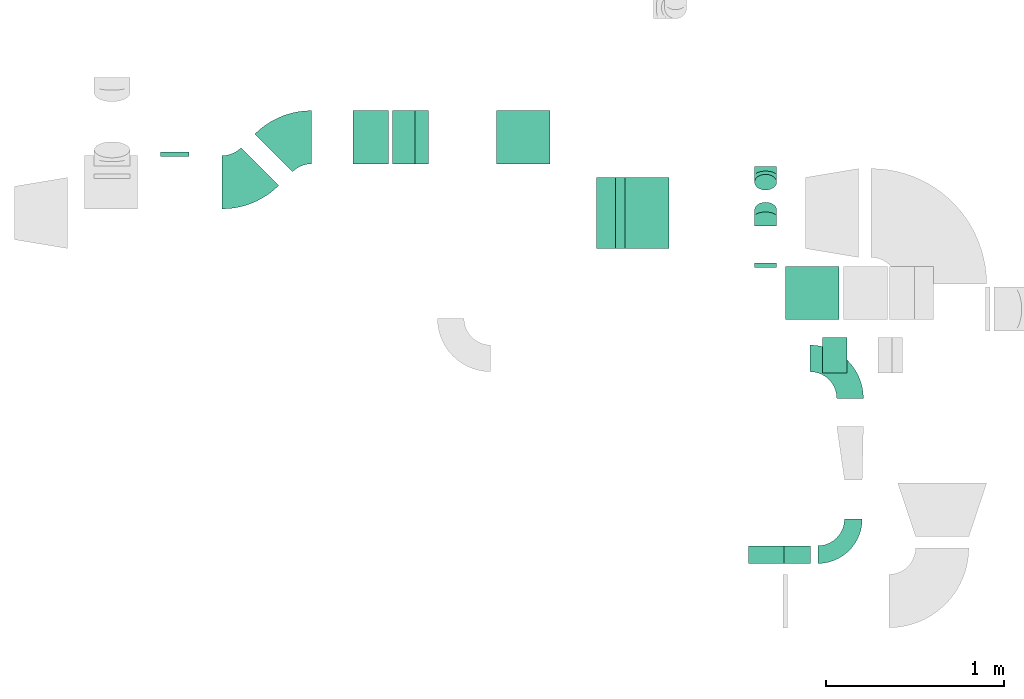
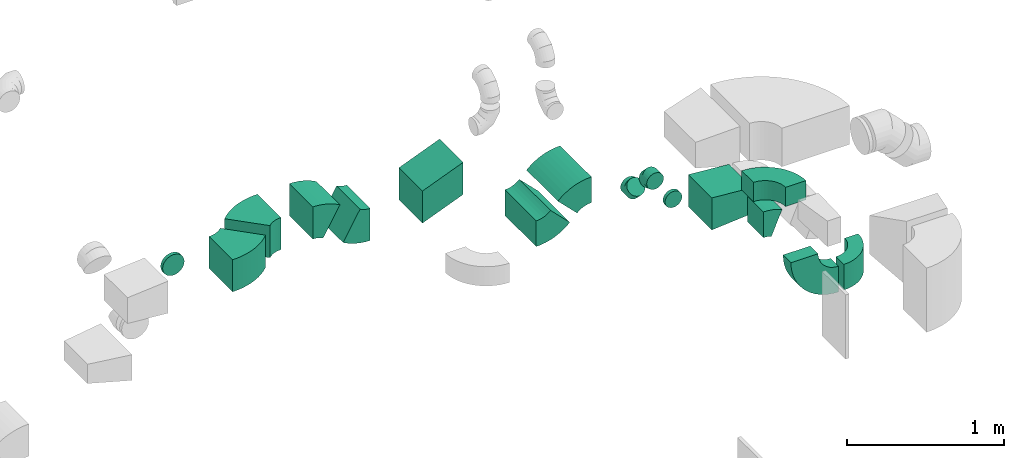
# One storey, part 26 of 44: 16 flow fittings.
"""IFC2X3 building model written with IfcOpenShell, lengths in millimetres."""

from ifc_helpers import new_model, entity, si_unit, converted_unit, derived_unit, direction, frame, frame_2d, origin, place, context, subcontext, project, spatial, polyline, circle_curve, parameter, trimmed, segment, composite_curve, outline, extrude, faceted_brep, source, transform, mapped, material, type_object, type_shapes, element, save


model = new_model("IFC2X3")

# Units and contexts
model_context = context("Model", 3, precision=0.01, world=origin(), true_north=direction((6.12303176911189e-17, 1.0)))
body_context = subcontext(model_context, "Body", "Model", "MODEL_VIEW")
ifc_project = project(units=[si_unit("LENGTHUNIT", "METRE", prefix="MILLI"), si_unit("AREAUNIT", "SQUARE_METRE"), si_unit("VOLUMEUNIT", "CUBIC_METRE"), converted_unit("PLANEANGLEUNIT", "DEGREE", entity("IfcRatioMeasure", 0.0174532925199433), si_unit("PLANEANGLEUNIT", "RADIAN"), dimensions=[0, 0, 0, 0, 0, 0, 0]), si_unit("MASSUNIT", "GRAM", prefix="KILO"), derived_unit("MASSDENSITYUNIT", [(si_unit("MASSUNIT", "GRAM", prefix="KILO"), 1), (si_unit("LENGTHUNIT", "METRE"), -3)]), derived_unit("MOMENTOFINERTIAUNIT", [(si_unit("LENGTHUNIT", "METRE"), 4)]), si_unit("TIMEUNIT", "SECOND"), si_unit("FREQUENCYUNIT", "HERTZ"), si_unit("THERMODYNAMICTEMPERATUREUNIT", "DEGREE_CELSIUS"), derived_unit("THERMALTRANSMITTANCEUNIT", [(si_unit("MASSUNIT", "GRAM", prefix="KILO"), 1), (si_unit("THERMODYNAMICTEMPERATUREUNIT", "KELVIN"), -1), (si_unit("TIMEUNIT", "SECOND"), -3)]), derived_unit("VOLUMETRICFLOWRATEUNIT", [(si_unit("LENGTHUNIT", "METRE"), 3), (si_unit("TIMEUNIT", "SECOND"), -1)]), derived_unit("MASSFLOWRATEUNIT", [(si_unit("MASSUNIT", "GRAM", prefix="KILO"), 1), (si_unit("TIMEUNIT", "SECOND"), -1)]), derived_unit("ROTATIONALFREQUENCYUNIT", [(si_unit("TIMEUNIT", "SECOND"), -1)]), si_unit("ELECTRICCURRENTUNIT", "AMPERE"), si_unit("ELECTRICVOLTAGEUNIT", "VOLT"), si_unit("POWERUNIT", "WATT"), si_unit("FORCEUNIT", "NEWTON", prefix="KILO"), si_unit("ILLUMINANCEUNIT", "LUX"), si_unit("LUMINOUSFLUXUNIT", "LUMEN"), si_unit("LUMINOUSINTENSITYUNIT", "CANDELA"), derived_unit("USERDEFINED", [(si_unit("MASSUNIT", "GRAM", prefix="KILO"), -1), (si_unit("LENGTHUNIT", "METRE"), -2), (si_unit("TIMEUNIT", "SECOND"), 3), (si_unit("LUMINOUSFLUXUNIT", "LUMEN"), 1)]), derived_unit("LINEARVELOCITYUNIT", [(si_unit("LENGTHUNIT", "METRE"), 1), (si_unit("TIMEUNIT", "SECOND"), -1)]), si_unit("PRESSUREUNIT", "PASCAL"), derived_unit("USERDEFINED", [(si_unit("LENGTHUNIT", "METRE"), -2), (si_unit("MASSUNIT", "GRAM", prefix="KILO"), 1), (si_unit("TIMEUNIT", "SECOND"), -2)]), derived_unit("LINEARFORCEUNIT", [(si_unit("MASSUNIT", "GRAM", prefix="KILO"), 1), (si_unit("LENGTHUNIT", "METRE"), 1), (si_unit("TIMEUNIT", "SECOND"), -2), (si_unit("LENGTHUNIT", "METRE"), -1)]), derived_unit("PLANARFORCEUNIT", [(si_unit("MASSUNIT", "GRAM", prefix="KILO"), 1), (si_unit("LENGTHUNIT", "METRE"), 1), (si_unit("TIMEUNIT", "SECOND"), -2), (si_unit("LENGTHUNIT", "METRE"), -2)])], contexts=[model_context])

# Site, building, storey
site_placement = place(None, origin())
site = spatial("IfcSite", under=ifc_project, at=site_placement, CompositionType="ELEMENT")
building_placement = place(site_placement, origin())
building = spatial("IfcBuilding", under=site, at=building_placement, CompositionType="ELEMENT")
storey_placement = place(building_placement, frame((0.0, 0.0, 15900.0)))
storey = spatial("IfcBuildingStorey", under=building, at=storey_placement, CompositionType="ELEMENT", Elevation=15900.0)

# Flow fittings
ifc_material = material()
duct_fitting_type_1 = type_object("IfcDuctFittingType", PredefinedType="NOTDEFINED", material=ifc_material)
shared_shape_1 = source(origin(), body_context, "Body", "SweptSolid", [
    extrude(outline(polyline([(-141.18, -112.11), (159.86, -112.11), (139.1, 137.03), (-157.79, 87.2), (-141.18, -112.11)])), frame((150.0, -150.0, 0.0), z_axis=(0.0, 1.0, 0.0), x_axis=(0.996545758244888, 0.0, 0.0830454798536443)), (0.0, 0.0, 1.0), 300.0),
])
type_shapes(duct_fitting_type_1, [shared_shape_1])
flow_fitting_1_placement = place(storey_placement, frame((53059.03, 14525.32, 3075.0), z_axis=(0.0, 0.0, 1.0), x_axis=(-1.0, 0.0, 0.0)))
element("IfcFlowFitting", 1, at=flow_fitting_1_placement, inside=storey, type_object=duct_fitting_type_1, material=ifc_material, context=body_context, shape_type="MappedRepresentation", body=[
    mapped(shared_shape_1, transform((0.0, 0.0, 0.0), scale=1.0)),
])
duct_fitting_type_2 = type_object("IfcDuctFittingType", PredefinedType="NOTDEFINED", material=ifc_material)
shared_shape_2 = source(origin(), body_context, "Body", "SweptSolid", [
    extrude(outline(polyline([(-207.34, -116.22), (115.32, -116.22), (207.34, 116.22), (-115.32, 116.22), (-207.34, -116.22)])), frame((150.0, -150.0, -59.38), z_axis=(0.0, 1.0, 0.0), x_axis=(0.929790028518496, 0.0, -0.368090346066796)), (0.0, 0.0, 1.0), 300.0),
])
type_shapes(duct_fitting_type_2, [shared_shape_2])
flow_fitting_2_placement = place(storey_placement, frame((51433.15, 15401.67, 3284.58), z_axis=(0.0, 0.0, 1.0), x_axis=(-1.0, 0.0, 0.0)))
element("IfcFlowFitting", 2, at=flow_fitting_2_placement, inside=storey, type_object=duct_fitting_type_2, material=ifc_material, context=body_context, shape_type="MappedRepresentation", body=[
    mapped(shared_shape_2, transform((0.0, 0.0, 0.0), scale=1.0)),
])
duct_fitting_type_3 = type_object("IfcDuctFittingType", PredefinedType="NOTDEFINED", material=ifc_material)
shared_shape_3 = source(origin(), body_context, "Body", "Brep", [
    faceted_brep([(-51.78, 0.0, -62.5), (-51.78, -16.18, -60.37), (-51.78, -31.25, -54.13), (-51.78, -44.19, -44.19), (-51.78, -54.13, -31.25), (-51.78, -60.37, -16.18), (-51.78, -62.5, 0.0), (-51.78, -60.37, 16.18), (-51.78, -54.13, 31.25), (-51.78, -44.19, 44.19), (-51.78, -31.25, 54.13), (-51.78, -16.18, 60.37), (-51.78, 0.0, 62.5), (-51.78, 16.18, 60.37), (-51.78, 31.25, 54.13), (-51.78, 44.19, 44.19), (-51.78, 54.13, 31.25), (-51.78, 60.37, 16.18), (-51.78, 62.5, 0.0), (-51.78, 60.37, -16.18), (-51.78, 54.13, -31.25), (-51.78, 44.19, -44.19), (-51.78, 31.25, -54.13), (-51.78, 16.18, -60.37), (-6.7, 16.18, 60.37), (-12.94, 31.25, 54.13), (0.0, 0.0, 62.5), (-18.31, 44.19, 44.19), (-22.42, 54.13, 31.25), (-25.01, 60.37, 16.18), (-25.89, 62.5, 0.0), (-25.01, 60.37, -16.18), (-22.42, 54.13, -31.25), (-18.31, 44.19, -44.19), (-6.7, 16.18, -60.37), (0.0, 0.0, -62.5), (-12.94, 31.25, -54.13), (6.7, -16.18, -60.37), (12.94, -31.25, -54.13), (18.31, -44.19, -44.19), (22.42, -54.13, -31.25), (25.01, -60.37, -16.18), (25.89, -62.5, 0.0), (25.01, -60.37, 16.18), (22.42, -54.13, 31.25), (18.31, -44.19, 44.19), (12.94, -31.25, 54.13), (6.7, -16.18, 60.37), (25.17, 48.05, 60.37), (14.51, 58.71, 54.13), (36.61, 36.61, 62.5), (5.36, 67.86, 44.19), (-1.66, 74.88, 31.25), (-6.08, 79.3, 16.18), (-7.58, 80.81, 0.0), (-6.08, 79.3, -16.18), (-1.66, 74.88, -31.25), (5.36, 67.86, -44.19), (14.51, 58.71, -54.13), (25.17, 48.05, -60.37), (36.61, 36.61, -62.5), (48.05, 25.17, -60.37), (58.71, 14.51, -54.13), (67.86, 5.36, -44.19), (74.88, -1.66, -31.25), (79.3, -6.08, -16.18), (80.81, -7.58, 0.0), (79.3, -6.08, 16.18), (74.88, -1.66, 31.25), (67.86, 5.36, 44.19), (58.71, 14.51, 54.13), (48.05, 25.17, 60.37)], [[[0, 1, 2, 3, 4, 5, 6, 7, 8, 9, 10, 11, 12, 13, 14, 15, 16, 17, 18, 19, 20, 21, 22, 23]], [[24, 25, 14, 13]], [[26, 24, 13, 12]], [[27, 15, 14, 25]], [[28, 29, 17, 16]], [[28, 16, 15, 27]], [[30, 18, 17, 29]], [[31, 32, 20, 19]], [[30, 31, 19, 18]], [[21, 20, 32, 33]], [[34, 35, 0, 23]], [[36, 34, 23, 22]], [[33, 36, 22, 21]], [[1, 0, 35, 37]], [[2, 1, 37, 38]], [[38, 39, 3, 2]], [[5, 4, 40, 41]], [[6, 5, 41, 42]], [[39, 40, 4, 3]], [[6, 42, 43, 7]], [[7, 43, 44, 8]], [[8, 44, 45, 9]], [[9, 45, 46, 10]], [[10, 46, 47, 11]], [[26, 12, 11, 47]], [[48, 49, 25, 24]], [[50, 48, 24, 26]], [[27, 25, 49, 51]], [[29, 28, 52, 53]], [[30, 29, 53, 54]], [[51, 52, 28, 27]], [[30, 54, 55, 31]], [[31, 55, 56, 32]], [[57, 33, 32, 56]], [[36, 58, 59, 34]], [[34, 59, 60, 35]], [[58, 36, 33, 57]], [[35, 60, 61, 37]], [[37, 61, 62, 38]], [[63, 39, 38, 62]], [[40, 64, 65, 41]], [[41, 65, 66, 42]], [[64, 40, 39, 63]], [[43, 42, 66, 67]], [[44, 43, 67, 68]], [[68, 69, 45, 44]], [[47, 46, 70, 71]], [[26, 47, 71, 50]], [[69, 70, 46, 45]], [[59, 58, 57, 56, 55, 54, 53, 52, 51, 49, 48, 50, 71, 70, 69, 68, 67, 66, 65, 64, 63, 62, 61, 60]]]),
])
type_shapes(duct_fitting_type_3, [shared_shape_3])
for number, where, z_axis, x_axis in (
    (3, (52646.56, 15185.32, 2820.0), (-1.0, 0.0, 0.0), (0.0, -1.0, 0.0)),
    (4, (52646.56, 14955.32, 3050.0), (1.0, 0.0, 0.0), (0.0, -0.707106781186459, 0.707106781186636)),
):
    element("IfcFlowFitting", number, at=place(storey_placement, frame(where, z_axis=z_axis, x_axis=x_axis)), inside=storey, type_object=duct_fitting_type_3, material=ifc_material, context=body_context, shape_type="MappedRepresentation", body=[
        mapped(shared_shape_3, transform((0.0, 0.0, 0.0), scale=1.0)),
    ])
duct_fitting_type_4 = type_object("IfcDuctFittingType", PredefinedType="NOTDEFINED", material=ifc_material)
shared_shape_4 = source(origin(), body_context, "Body", "Brep", [
    faceted_brep([(20.0, 16.18, -60.37), (20.0, 31.25, -54.13), (20.0, 44.19, -44.19), (20.0, 54.13, -31.25), (20.0, 60.37, -16.18), (20.0, 62.5, 0.0), (20.0, 60.37, 16.18), (20.0, 54.13, 31.25), (20.0, 44.19, 44.19), (20.0, 31.25, 54.13), (20.0, 16.18, 60.37), (20.0, 0.0, 62.5), (20.0, -16.18, 60.37), (20.0, -31.25, 54.13), (20.0, -44.19, 44.19), (20.0, -54.13, 31.25), (20.0, -60.37, 16.18), (20.0, -62.5, 0.0), (20.0, -60.37, -16.18), (20.0, -54.13, -31.25), (20.0, -44.19, -44.19), (20.0, -31.25, -54.13), (20.0, -16.18, -60.37), (20.0, 0.0, -62.5), (0.0, 0.0, 62.5), (0.0, 16.18, 60.37), (-6.1, 16.18, 60.37), (-6.1, 0.0, 62.5), (0.0, 31.25, 54.13), (-6.1, 31.25, 54.13), (0.0, 44.19, 44.19), (-6.1, 44.19, 44.19), (0.0, 54.13, 31.25), (0.0, 60.37, 16.18), (-6.1, 60.37, 16.18), (-6.1, 54.13, 31.25), (0.0, 62.5, 0.0), (-6.1, 62.5, 0.0), (0.0, 60.37, -16.18), (-6.1, 60.37, -16.18), (0.0, 54.13, -31.25), (-6.1, 54.13, -31.25), (0.0, 44.19, -44.19), (-6.1, 44.19, -44.19), (0.0, 31.25, -54.13), (0.0, 16.18, -60.37), (-6.1, 16.18, -60.37), (-6.1, 31.25, -54.13), (0.0, 0.0, -62.5), (-6.1, 0.0, -62.5), (0.0, -16.18, -60.37), (-6.1, -16.18, -60.37), (0.0, -31.25, -54.13), (-6.1, -31.25, -54.13), (0.0, -44.19, -44.19), (-6.1, -44.19, -44.19), (0.0, -54.13, -31.25), (0.0, -60.37, -16.18), (-6.1, -60.37, -16.18), (-6.1, -54.13, -31.25), (0.0, -62.5, 0.0), (-6.1, -62.5, 0.0), (0.0, -60.37, 16.18), (-6.1, -60.37, 16.18), (0.0, -54.13, 31.25), (-6.1, -54.13, 31.25), (0.0, -44.19, 44.19), (-6.1, -44.19, 44.19), (0.0, -31.25, 54.13), (0.0, -16.18, 60.37), (-6.1, -16.18, 60.37), (-6.1, -31.25, 54.13)], [[[0, 1, 2, 3, 4, 5, 6, 7, 8, 9, 10, 11, 12, 13, 14, 15, 16, 17, 18, 19, 20, 21, 22, 23]], [[24, 11, 10, 25, 26, 27]], [[25, 10, 9, 28, 29, 26]], [[28, 9, 8, 30, 31, 29]], [[32, 7, 6, 33, 34, 35]], [[33, 6, 5, 36, 37, 34]], [[30, 8, 7, 32, 35, 31]], [[36, 5, 4, 38, 39, 37]], [[38, 4, 3, 40, 41, 39]], [[40, 3, 2, 42, 43, 41]], [[44, 1, 0, 45, 46, 47]], [[45, 0, 23, 48, 49, 46]], [[42, 2, 1, 44, 47, 43]], [[48, 23, 22, 50, 51, 49]], [[50, 22, 21, 52, 53, 51]], [[52, 21, 20, 54, 55, 53]], [[56, 19, 18, 57, 58, 59]], [[57, 18, 17, 60, 61, 58]], [[54, 20, 19, 56, 59, 55]], [[60, 17, 16, 62, 63, 61]], [[62, 16, 15, 64, 65, 63]], [[64, 15, 14, 66, 67, 65]], [[68, 13, 12, 69, 70, 71]], [[69, 12, 11, 24, 27, 70]], [[66, 14, 13, 68, 71, 67]], [[49, 51, 53, 55, 59, 58, 61, 63, 65, 67, 71, 70, 27, 26, 29, 31, 35, 34, 37, 39, 41, 43, 47, 46]]]),
])
type_shapes(duct_fitting_type_4, [shared_shape_4])
flow_fitting_3_placement = place(storey_placement, frame((52646.56, 14675.32, 3050.0), z_axis=(0.0, 0.0, -1.0), x_axis=(0.0, 1.0, 0.0)))
element("IfcFlowFitting", 5, at=flow_fitting_3_placement, inside=storey, type_object=duct_fitting_type_4, material=ifc_material, context=body_context, shape_type="MappedRepresentation", body=[
    mapped(shared_shape_4, transform((0.0, 0.0, 0.0), scale=1.0)),
])
duct_fitting_type_5 = type_object("IfcDuctFittingType", PredefinedType="NOTDEFINED", material=ifc_material)
shared_shape_5 = source(origin(), body_context, "Body", "Brep", [
    faceted_brep([(20.0, 20.71, -77.27), (20.0, 40.0, -69.28), (20.0, 56.57, -56.57), (20.0, 69.28, -40.0), (20.0, 77.27, -20.71), (20.0, 80.0, 0.0), (20.0, 77.27, 20.71), (20.0, 69.28, 40.0), (20.0, 56.57, 56.57), (20.0, 40.0, 69.28), (20.0, 20.71, 77.27), (20.0, 0.0, 80.0), (20.0, -20.71, 77.27), (20.0, -40.0, 69.28), (20.0, -56.57, 56.57), (20.0, -69.28, 40.0), (20.0, -77.27, 20.71), (20.0, -80.0, 0.0), (20.0, -77.27, -20.71), (20.0, -69.28, -40.0), (20.0, -56.57, -56.57), (20.0, -40.0, -69.28), (20.0, -20.71, -77.27), (20.0, 0.0, -80.0), (0.0, 0.0, 80.0), (0.0, 20.71, 77.27), (-6.1, 20.71, 77.27), (-6.1, 0.0, 80.0), (0.0, 40.0, 69.28), (-6.1, 40.0, 69.28), (0.0, 56.57, 56.57), (-6.1, 56.57, 56.57), (0.0, 69.28, 40.0), (0.0, 77.27, 20.71), (-6.1, 77.27, 20.71), (-6.1, 69.28, 40.0), (0.0, 80.0, 0.0), (-6.1, 80.0, 0.0), (0.0, 77.27, -20.71), (-6.1, 77.27, -20.71), (0.0, 69.28, -40.0), (-6.1, 69.28, -40.0), (0.0, 56.57, -56.57), (-6.1, 56.57, -56.57), (0.0, 40.0, -69.28), (0.0, 20.71, -77.27), (-6.1, 20.71, -77.27), (-6.1, 40.0, -69.28), (0.0, 0.0, -80.0), (-6.1, 0.0, -80.0), (0.0, -20.71, -77.27), (-6.1, -20.71, -77.27), (0.0, -40.0, -69.28), (-6.1, -40.0, -69.28), (0.0, -56.57, -56.57), (-6.1, -56.57, -56.57), (0.0, -69.28, -40.0), (0.0, -77.27, -20.71), (-6.1, -77.27, -20.71), (-6.1, -69.28, -40.0), (0.0, -80.0, 0.0), (-6.1, -80.0, 0.0), (0.0, -77.27, 20.71), (-6.1, -77.27, 20.71), (0.0, -69.28, 40.0), (-6.1, -69.28, 40.0), (0.0, -56.57, 56.57), (-6.1, -56.57, 56.57), (0.0, -40.0, 69.28), (0.0, -20.71, 77.27), (-6.1, -20.71, 77.27), (-6.1, -40.0, 69.28)], [[[0, 1, 2, 3, 4, 5, 6, 7, 8, 9, 10, 11, 12, 13, 14, 15, 16, 17, 18, 19, 20, 21, 22, 23]], [[24, 11, 10, 25, 26, 27]], [[25, 10, 9, 28, 29, 26]], [[28, 9, 8, 30, 31, 29]], [[32, 7, 6, 33, 34, 35]], [[33, 6, 5, 36, 37, 34]], [[30, 8, 7, 32, 35, 31]], [[36, 5, 4, 38, 39, 37]], [[38, 4, 3, 40, 41, 39]], [[40, 3, 2, 42, 43, 41]], [[44, 1, 0, 45, 46, 47]], [[45, 0, 23, 48, 49, 46]], [[42, 2, 1, 44, 47, 43]], [[48, 23, 22, 50, 51, 49]], [[50, 22, 21, 52, 53, 51]], [[52, 21, 20, 54, 55, 53]], [[56, 19, 18, 57, 58, 59]], [[57, 18, 17, 60, 61, 58]], [[54, 20, 19, 56, 59, 55]], [[60, 17, 16, 62, 63, 61]], [[62, 16, 15, 64, 65, 63]], [[64, 15, 14, 66, 67, 65]], [[68, 13, 12, 69, 70, 71]], [[69, 12, 11, 24, 27, 70]], [[66, 14, 13, 68, 71, 67]], [[49, 51, 53, 55, 59, 58, 61, 63, 65, 67, 71, 70, 27, 26, 29, 31, 35, 34, 37, 39, 41, 43, 47, 46]]]),
])
type_shapes(duct_fitting_type_5, [shared_shape_5])
flow_fitting_4_placement = place(storey_placement, frame((49322.84, 15298.63, 3325.0), z_axis=(0.0, 0.0, -1.0), x_axis=(0.0, 1.0, 0.0)))
element("IfcFlowFitting", 6, at=flow_fitting_4_placement, inside=storey, type_object=duct_fitting_type_5, material=ifc_material, context=body_context, shape_type="MappedRepresentation", body=[
    mapped(shared_shape_5, transform((0.0, 0.0, 0.0), scale=1.0)),
])
duct_fitting_type_6 = type_object("IfcDuctFittingType", PredefinedType="NOTDEFINED", material=ifc_material)
shared_shape_6 = source(origin(), body_context, "Body", "SweptSolid", [
    extrude(outline(composite_curve([segment(polyline([(-187.5, -112.5), (-37.5, -112.5)]), True, "CONTINUOUS"), segment(trimmed(circle_curve(frame_2d((112.5, -112.5), x_axis=(0.0, 1.0)), 150.0), [parameter(0.0)], [parameter(90.0000000000001)], True, "PARAMETER"), False, "CONTINUOUS"), segment(polyline([(112.5, 37.5), (112.5, 187.5)]), True, "CONTINUOUS"), segment(trimmed(circle_curve(frame_2d((112.5, -112.5), x_axis=(0.0, 1.0)), 300.0), [parameter(0.0)], [parameter(90.0000000000001)], True, "PARAMETER"), True, "CONTINUOUS")], self_intersect=False)), frame((-112.5, 112.5, -75.0), z_axis=(0.0, 0.0, 1.0), x_axis=(-1.0, 0.0, 0.0)), (0.0, 0.0, 1.0), 150.0),
])
type_shapes(duct_fitting_type_6, [shared_shape_6])
flow_fitting_5_placement = place(storey_placement, frame((53121.72, 14157.73, 3375.0), z_axis=(0.0, 0.0, 1.0), x_axis=(0.0, 1.0, 0.0)))
element("IfcFlowFitting", 7, at=flow_fitting_5_placement, inside=storey, type_object=duct_fitting_type_6, material=ifc_material, context=body_context, shape_type="MappedRepresentation", body=[
    mapped(shared_shape_6, transform((0.0, 0.0, 0.0), scale=1.0)),
])
duct_fitting_type_7 = type_object("IfcDuctFittingType", PredefinedType="NOTDEFINED", material=ifc_material)
shared_shape_7 = source(origin(), body_context, "Body", "SweptSolid", [
    extrude(outline(composite_curve([segment(polyline([(-136.61, -88.39), (63.39, -88.39)]), True, "CONTINUOUS"), segment(trimmed(circle_curve(frame_2d((213.39, -88.39), x_axis=(-0.707106781186546, 0.707106781186546)), 150.0), [parameter(0.0)], [parameter(45.0)], True, "PARAMETER"), False, "CONTINUOUS"), segment(polyline([(107.32, 17.68), (-34.1, 159.1)]), True, "CONTINUOUS"), segment(trimmed(circle_curve(frame_2d((213.39, -88.39), x_axis=(-0.707106781186546, 0.707106781186546)), 350.0), [parameter(0.0)], [parameter(45.0)], True, "PARAMETER"), True, "CONTINUOUS")], self_intersect=False)), frame((-15.17, 36.61, -200.0), z_axis=(0.0, 0.0, 1.0), x_axis=(-0.707106781186547, 0.707106781186548, 0.0)), (0.0, 0.0, 1.0), 400.0),
])
type_shapes(duct_fitting_type_7, [shared_shape_7])
for number, where, z_axis, x_axis in (
    (8, (52000.04, 14975.52, 3250.0), (0.0, -1.0, 0.0), (-1.0, 0.0, 0.0)),
    (9, (51800.04, 14975.52, 3050.0), (0.0, 1.0, 0.0), (-0.707106781186501, 0.0, -0.707106781186595)),
):
    element("IfcFlowFitting", number, at=place(storey_placement, frame(where, z_axis=z_axis, x_axis=x_axis)), inside=storey, type_object=duct_fitting_type_7, material=ifc_material, context=body_context, shape_type="MappedRepresentation", body=[
        mapped(shared_shape_7, transform((0.0, 0.0, 0.0), scale=1.0)),
    ])
duct_fitting_type_8 = type_object("IfcDuctFittingType", PredefinedType="NOTDEFINED", material=ifc_material)
shared_shape_8 = source(origin(), body_context, "Body", "SweptSolid", [
    extrude(outline(composite_curve([segment(polyline([(-150.0, -100.0), (-50.0, -100.0)]), True, "CONTINUOUS"), segment(trimmed(circle_curve(frame_2d((100.0, -100.0), x_axis=(0.0, 1.0)), 150.0), [parameter(0.0)], [parameter(90.0000000000001)], True, "PARAMETER"), False, "CONTINUOUS"), segment(polyline([(100.0, 50.0), (100.0, 150.0)]), True, "CONTINUOUS"), segment(trimmed(circle_curve(frame_2d((100.0, -100.0), x_axis=(0.0, 1.0)), 250.0), [parameter(0.0)], [parameter(90.0000000000001)], True, "PARAMETER"), True, "CONTINUOUS")], self_intersect=False)), frame((-100.0, 100.0, -100.0), z_axis=(0.0, 0.0, 1.0), x_axis=(-1.0, 0.0, 0.0)), (0.0, 0.0, 1.0), 200.0),
])
type_shapes(duct_fitting_type_8, [shared_shape_8])
flow_fitting_6_placement = place(storey_placement, frame((53139.92, 13053.66, 3350.0)))
element("IfcFlowFitting", 10, at=flow_fitting_6_placement, inside=storey, type_object=duct_fitting_type_8, material=ifc_material, context=body_context, shape_type="MappedRepresentation", body=[
    mapped(shared_shape_8, transform((0.0, 0.0, 0.0), scale=1.0)),
])
duct_fitting_type_9 = type_object("IfcDuctFittingType", PredefinedType="NOTDEFINED", material=ifc_material)
shared_shape_9 = source(origin(), body_context, "Body", "SweptSolid", [
    extrude(outline(composite_curve([segment(polyline([(-225.0, -125.0), (-25.0, -125.0)]), True, "CONTINUOUS"), segment(trimmed(circle_curve(frame_2d((125.0, -125.0), x_axis=(0.0, 1.0)), 150.0), [parameter(0.0)], [parameter(90.0000000000001)], True, "PARAMETER"), False, "CONTINUOUS"), segment(polyline([(125.0, 25.0), (125.0, 225.0)]), True, "CONTINUOUS"), segment(trimmed(circle_curve(frame_2d((125.0, -125.0), x_axis=(0.0, 1.0)), 350.0), [parameter(0.0)], [parameter(90.0000000000001)], True, "PARAMETER"), True, "CONTINUOUS")], self_intersect=False)), frame((-125.0, 125.0, -50.0), z_axis=(0.0, 0.0, 1.0), x_axis=(-1.0, 0.0, 0.0)), (0.0, 0.0, 1.0), 100.0),
])
type_shapes(duct_fitting_type_9, [shared_shape_9])
flow_fitting_7_placement = place(storey_placement, frame((52649.92, 13053.66, 3350.0), z_axis=(0.0, 1.0, 0.0), x_axis=(-1.0, 0.0, 0.0)))
element("IfcFlowFitting", 11, at=flow_fitting_7_placement, inside=storey, type_object=duct_fitting_type_9, material=ifc_material, context=body_context, shape_type="MappedRepresentation", body=[
    mapped(shared_shape_9, transform((0.0, 0.0, 0.0), scale=1.0)),
])
duct_fitting_type_10 = type_object("IfcDuctFittingType", PredefinedType="NOTDEFINED", material=ifc_material)
shared_shape_10 = source(origin(), body_context, "Body", "SweptSolid", [
    extrude(outline(composite_curve([segment(polyline([(-193.93, -106.07), (106.07, -106.07)]), True, "CONTINUOUS"), segment(trimmed(circle_curve(frame_2d((256.07, -106.07), x_axis=(-0.707106781186553, 0.707106781186553)), 150.0), [parameter(0.0)], [parameter(45.0)], True, "PARAMETER"), False, "CONTINUOUS"), segment(polyline([(150.0, 0.0), (-62.13, 212.13)]), True, "CONTINUOUS"), segment(trimmed(circle_curve(frame_2d((256.07, -106.07), x_axis=(-0.707106781186553, 0.707106781186553)), 450.0), [parameter(0.0)], [parameter(45.0)], True, "PARAMETER"), True, "CONTINUOUS")], self_intersect=False)), frame((-18.2, 43.93, -125.0), z_axis=(0.0, 0.0, 1.0), x_axis=(-0.707106781186547, 0.707106781186548, 0.0)), (0.0, 0.0, 1.0), 250.0),
])
type_shapes(duct_fitting_type_10, [shared_shape_10])
flow_fitting_8_placement = place(storey_placement, frame((49713.9, 15148.63, 3325.02)))
element("IfcFlowFitting", 12, at=flow_fitting_8_placement, inside=storey, type_object=duct_fitting_type_10, material=ifc_material, context=body_context, shape_type="MappedRepresentation", body=[
    mapped(shared_shape_10, transform((0.0, 0.0, 0.0), scale=1.0)),
])
flow_fitting_9_placement = place(storey_placement, frame((49966.94, 15401.67, 3325.02), z_axis=(0.0, 0.0, 1.0), x_axis=(-1.0, 0.0, 0.0)))
element("IfcFlowFitting", 13, at=flow_fitting_9_placement, inside=storey, type_object=duct_fitting_type_10, material=ifc_material, context=body_context, shape_type="MappedRepresentation", body=[
    mapped(shared_shape_10, transform((0.0, 0.0, 0.0), scale=1.0)),
])
duct_fitting_type_11 = type_object("IfcDuctFittingType", PredefinedType="NOTDEFINED", material=ifc_material)
shared_shape_11 = source(origin(), body_context, "Body", "SweptSolid", [
    extrude(outline(composite_curve([segment(polyline([(-143.42, -68.75), (106.58, -68.75)]), True, "CONTINUOUS"), segment(trimmed(circle_curve(frame_2d((256.58, -68.75), x_axis=(-0.866025035284224, 0.500000638260552)), 150.0), [parameter(0.0)], [parameter(30.0000422269872)], True, "PARAMETER"), False, "CONTINUOUS"), segment(polyline([(126.67, 6.25), (-89.83, 131.25)]), True, "CONTINUOUS"), segment(trimmed(circle_curve(frame_2d((256.58, -68.75), x_axis=(-0.866025035284224, 0.500000638260552)), 400.0), [parameter(0.0)], [parameter(30.0000422269872)], True, "PARAMETER"), True, "CONTINUOUS")], self_intersect=False)), frame((-4.94, 18.42, -150.0), z_axis=(0.0, 0.0, 1.0), x_axis=(-0.500000638260552, 0.866025035284224, 0.0)), (0.0, 0.0, 1.0), 300.0),
])
type_shapes(duct_fitting_type_11, [shared_shape_11])
for number, where, z_axis, x_axis in (
    (14, (50675.11, 15401.67, 3165.81), (0.0, 1.0, 0.0), (-1.0, 0.0, 0.0)),
    (15, (50399.36, 15401.67, 3325.02), (0.0, -1.0, 0.0), (-0.866025035284201, 0.0, 0.500000638260591)),
):
    element("IfcFlowFitting", number, at=place(storey_placement, frame(where, z_axis=z_axis, x_axis=x_axis)), inside=storey, type_object=duct_fitting_type_11, material=ifc_material, context=body_context, shape_type="MappedRepresentation", body=[
        mapped(shared_shape_11, transform((0.0, 0.0, 0.0), scale=1.0)),
    ])
duct_fitting_type_12 = type_object("IfcDuctFittingType", PredefinedType="NOTDEFINED", material=ifc_material)
shared_shape_12 = source(origin(), body_context, "Body", "SweptSolid", [
    extrude(outline(composite_curve([segment(polyline([(-110.16, -49.36), (89.84, -49.36)]), True, "CONTINUOUS"), segment(trimmed(circle_curve(frame_2d((239.84, -49.36), x_axis=(-0.918736047311617, 0.394872226638217)), 150.0), [parameter(0.0)], [parameter(23.2580054037017)], True, "PARAMETER"), False, "CONTINUOUS"), segment(polyline([(102.03, 9.87), (-81.72, 88.85)]), True, "CONTINUOUS"), segment(trimmed(circle_curve(frame_2d((239.84, -49.36), x_axis=(-0.918736047311617, 0.394872226638217)), 350.0), [parameter(0.0)], [parameter(23.2580054037017)], True, "PARAMETER"), True, "CONTINUOUS")], self_intersect=False)), frame((-2.09, 10.16, -100.0), z_axis=(0.0, 0.0, 1.0), x_axis=(-0.394872226638217, 0.918736047311618, 0.0)), (0.0, 0.0, 1.0), 200.0),
])
type_shapes(duct_fitting_type_12, [shared_shape_12])
flow_fitting_10_placement = place(storey_placement, frame((53017.08, 14175.53, 3100.0), z_axis=(0.0, -1.0, 0.0), x_axis=(-0.918736047311585, 0.0, 0.394872226638296)))
element("IfcFlowFitting", 16, at=flow_fitting_10_placement, inside=storey, type_object=duct_fitting_type_12, material=ifc_material, context=body_context, shape_type="MappedRepresentation", body=[
    mapped(shared_shape_12, transform((0.0, 0.0, 0.0), scale=1.0)),
])

save(model, "model.ifc")
